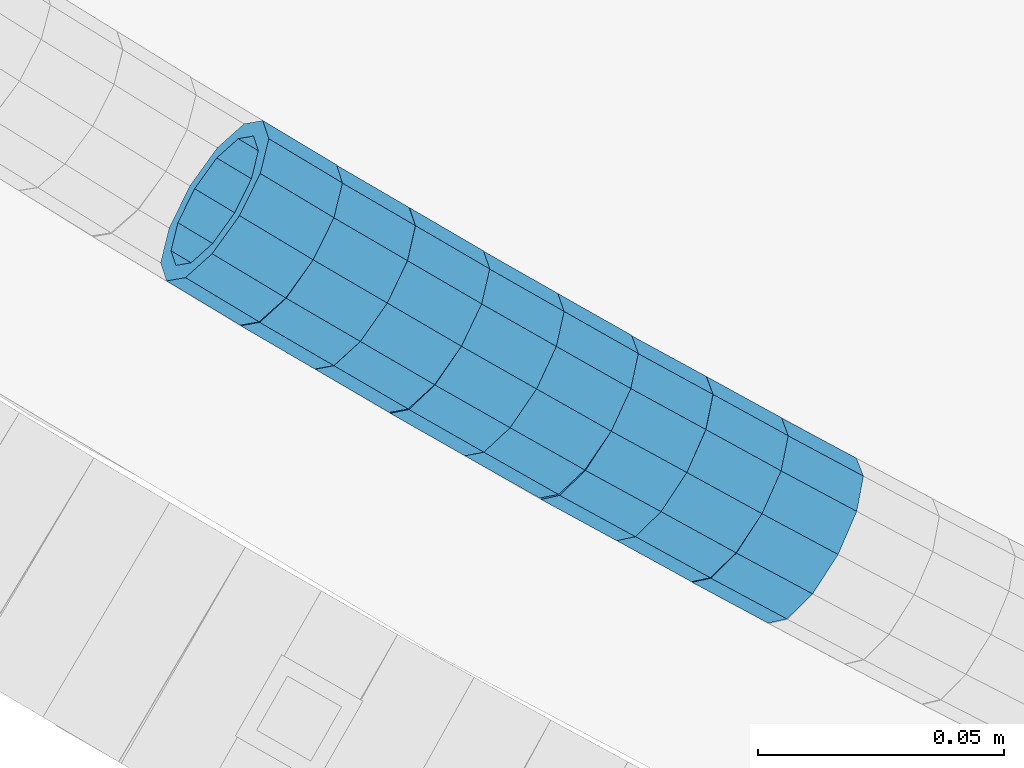
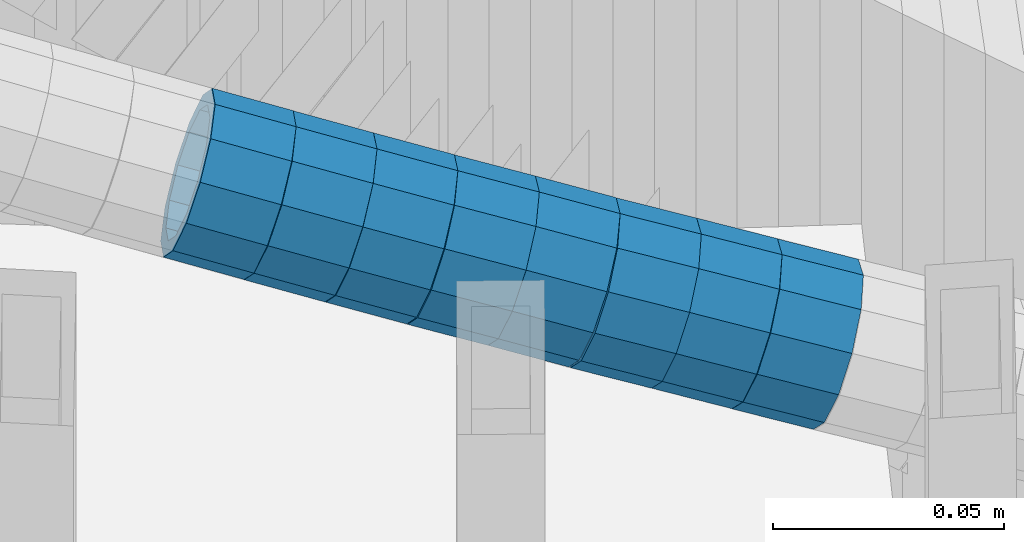
# One storey, part 646 of 975: 8 beams.
"""IFC2X3 building model written with IfcOpenShell, lengths in millimetres."""

from ifc_helpers import new_model, si_unit, frame, origin_with_axes, place, context, subcontext, project, spatial, faceted_brep, material, type_object, element, save


model = new_model("IFC2X3")

# Units and contexts
model_context = context("Model", 3, precision=1e-05, world=origin_with_axes())
body_context = subcontext(model_context, "Body", "Model", "MODEL_VIEW")
ifc_project = project(units=[si_unit("LENGTHUNIT", "METRE", prefix="MILLI"), si_unit("AREAUNIT", "SQUARE_METRE"), si_unit("VOLUMEUNIT", "CUBIC_METRE"), si_unit("MASSUNIT", "GRAM", prefix="KILO"), si_unit("TIMEUNIT", "SECOND"), si_unit("PLANEANGLEUNIT", "RADIAN"), si_unit("SOLIDANGLEUNIT", "STERADIAN"), si_unit("THERMODYNAMICTEMPERATUREUNIT", "DEGREE_CELSIUS"), si_unit("LUMINOUSINTENSITYUNIT", "LUMEN")], contexts=[model_context])

# Site, building, storey
site_placement = place(None, origin_with_axes())
site = spatial("IfcSite", under=ifc_project, at=site_placement, CompositionType="ELEMENT")
building_placement = place(site_placement, origin_with_axes())
building = spatial("IfcBuilding", under=site, at=building_placement, Name="Undefined", CompositionType="ELEMENT")
storey_placement = place(building_placement, origin_with_axes())
storey = spatial("IfcBuildingStorey", under=building, at=storey_placement, Name="Undefined", CompositionType="ELEMENT", Elevation=0.0)

# Beams
ifc_material = material()
beam_type = type_object("IfcBeamType", PredefinedType="NOTDEFINED")
beam_1_placement = place(storey_placement, frame((33294.3357173171, 1016.54392935502, 4704.68731766489), z_axis=(0.514495754965712, 0.857492925989633, 7.84348230808974e-12), x_axis=(0.815301680931507, -0.489181007958907, -0.309814638973963)))
element("IfcBeam", 1, at=beam_1_placement, inside=storey, type_object=beam_type, material=ifc_material, Name="WALL", context=body_context, shape_type="Brep", body=[
    faceted_brep([(-2.1246523829177e-07, -15.367000000002, 0.0), (-1.83998054126278e-07, -13.3082123799541, 7.68350000000009), (18.4002717371586, -13.3082123799486, 7.6835000000101), (18.4002717371732, -15.3670000000002, 2.5465851649642e-11), (-1.06232619145885e-07, -7.68349999999919, 13.3082123799559), (18.4002717371368, -7.68349999998645, 13.3082123799431), (-3.63797880709171e-12, 3.63797880709171e-12, 15.3670000000002), (18.400271737115, 2.00088834390044e-11, 15.3669999999656), (1.06225343188271e-07, 7.68350000000646, 13.3082123799559), (18.4002717371004, 7.68350000002283, 13.3082123799068), (1.8399441614747e-07, 13.308212379965, 7.68350000000009), (18.4002717370895, 13.3082123799741, 7.68349999994462), (2.12461600312963e-07, 15.3670000000093, 0.0), (18.4002717370931, 15.3670000000147, -5.45696821063757e-11), (1.8399441614747e-07, 13.308212379965, -7.68350000000009), (18.4002717371004, 13.3082123799632, -7.6835000000392), (1.06225343188271e-07, 7.68350000000646, -13.3082123799559), (18.4002717371259, 7.68349999999919, -13.3082123799759), (-3.63797880709171e-12, 3.63797880709171e-12, -15.3670000000002), (18.4002717371513, -5.45696821063757e-12, -15.3669999999984), (-1.06232619145885e-07, -7.68349999999919, -13.3082123799559), (18.4002717371659, -7.68350000000646, -13.3082123799395), (-1.83998054126278e-07, -13.3082123799541, -7.68350000000009), (18.4002717371732, -13.3082123799613, -7.68349999997736), (-2.63386027654633e-07, -19.0500000000029, 0.0), (-2.28097633225843e-07, -16.4977839420972, -9.52499999999964), (18.4002717371877, -16.4977839421026, -9.52499999996508), (18.4002717371841, -19.0500000000029, 3.63797880709171e-11), (-1.31691194837913e-07, -9.52500000000146, -16.4977839420935), (18.4002717371768, -9.52500000001055, -16.4977839420681), (-3.63797880709171e-12, 3.63797880709171e-12, -19.0500000000002), (18.400271737155, -9.09494701772928e-12, -19.0499999999956), (1.31687556859106e-07, 9.52500000000509, -16.4977839420935), (18.4002717371295, 9.52499999999782, -16.4977839421153), (2.28097633225843e-07, 16.4977839421044, -9.52499999999964), (18.4002717370968, 16.4977839421026, -9.52500000005239), (2.63382389675826e-07, 19.0500000000138, 0.0), (18.4002717370822, 19.0500000000156, -6.54836185276508e-11), (2.28097633225843e-07, 16.4977839421044, 9.52499999999964), (18.4002717370786, 16.4977839421172, 9.52499999993233), (1.31687556859106e-07, 9.52500000000509, 16.4977839420935), (18.4002717370859, 9.5250000000251, 16.497783942039), (-3.63797880709171e-12, 3.63797880709171e-12, 19.0500000000002), (18.4002717371113, 2.36468622460961e-11, 19.0499999999629), (-1.31691194837913e-07, -9.52500000000146, 16.4977839420935), (18.4002717371368, -9.52499999998327, 16.4977839420826), (-2.28097633225843e-07, -16.4977839420972, 9.52499999999964), (18.4002717371623, -16.4977839420844, 9.52500000001601)], [[[0, 1, 2, 3]], [[1, 4, 5, 2]], [[4, 6, 7, 5]], [[6, 8, 9, 7]], [[8, 10, 11, 9]], [[10, 12, 13, 11]], [[12, 14, 15, 13]], [[14, 16, 17, 15]], [[16, 18, 19, 17]], [[18, 20, 21, 19]], [[20, 22, 23, 21]], [[22, 0, 3, 23]], [[24, 25, 26, 27]], [[25, 28, 29, 26]], [[28, 30, 31, 29]], [[30, 32, 33, 31]], [[32, 34, 35, 33]], [[34, 36, 37, 35]], [[36, 38, 39, 37]], [[38, 40, 41, 39]], [[40, 42, 43, 41]], [[42, 44, 45, 43]], [[44, 46, 47, 45]], [[46, 24, 27, 47]], [[29, 31, 33, 35, 37, 39, 41, 43, 45, 47, 27, 26], [5, 7, 9, 11, 13, 15, 17, 19, 21, 23, 3, 2]], [[46, 44, 42, 40, 38, 36, 34, 32, 30, 28, 25, 24], [22, 20, 18, 16, 14, 12, 10, 8, 6, 4, 1, 0]]]),
])
beam_2_placement = place(storey_placement, frame((33309.2125258696, 1007.52858178118, 4699.01962007221), z_axis=(0.503515225322365, 0.863986352825418, -1.21602170111146e-10), x_axis=(0.820010580827939, -0.47788696089976, -0.314970950933919)))
element("IfcBeam", 2, at=beam_2_placement, inside=storey, type_object=beam_type, material=ifc_material, Name="WALL", context=body_context, shape_type="Brep", body=[
    faceted_brep([(-2.1246523829177e-07, -15.367000000002, 0.0), (-1.83998054126278e-07, -13.3082123799541, 7.68350000000009), (18.4143965418989, -13.3082123799722, 7.68350000004284), (18.4143965419134, -15.3670000000257, 5.82076609134674e-11), (-1.06232619145885e-07, -7.68349999999919, 13.3082123799559), (18.4143965418734, -7.68350000000646, 13.3082123799759), (-3.63797880709171e-12, 3.63797880709171e-12, 15.3670000000002), (18.414396541848, 3.63797880709171e-12, 15.3669999999984), (1.06225343188271e-07, 7.68350000000646, 13.3082123799559), (18.4143965418334, 7.6835000000101, 13.3082123799395), (1.8399441614747e-07, 13.308212379965, 7.68350000000009), (18.4143965418261, 13.3082123799686, 7.68349999997736), (2.12461600312963e-07, 15.3670000000093, 0.0), (18.4143965418334, 15.3670000000093, -1.81898940354586e-11), (1.8399441614747e-07, 13.308212379965, -7.68350000000009), (18.4143965418552, 13.3082123799577, -7.68349999999919), (1.06225343188271e-07, 7.68350000000646, -13.3082123799559), (18.4143965418734, 7.68349999999191, -13.3082123799322), (-3.63797880709171e-12, 3.63797880709171e-12, -15.3670000000002), (18.4143965418989, -2.00088834390044e-11, -15.3669999999584), (-1.06232619145885e-07, -7.68349999999919, -13.3082123799559), (18.4143965419134, -7.68350000002829, -13.3082123798958), (-1.83998054126278e-07, -13.3082123799541, -7.68350000000009), (18.4143965419207, -13.3082123799832, -7.6834999999337), (-2.63386027654633e-07, -19.0500000000029, 0.0), (-2.28097633225843e-07, -16.4977839420972, -9.52499999999964), (18.4143965419316, -16.4977839421263, -9.5249999999287), (18.4143965419207, -19.0500000000284, 6.54836185276508e-11), (-1.31691194837913e-07, -9.52500000000146, -16.4977839420935), (18.4143965419207, -9.52500000003056, -16.497783942028), (-3.63797880709171e-12, 3.63797880709171e-12, -19.0500000000002), (18.4143965419025, -2.18278728425503e-11, -19.049999999952), (1.31687556859106e-07, 9.52500000000509, -16.4977839420935), (18.4143965418771, 9.52499999999054, -16.4977839420717), (2.28097633225843e-07, 16.4977839421044, -9.52499999999964), (18.414396541848, 16.4977839420972, -9.52500000000146), (2.63382389675826e-07, 19.0500000000138, 0.0), (18.4143965418298, 19.050000000012, -2.18278728425503e-11), (2.28097633225843e-07, 16.4977839421044, 9.52499999999964), (18.4143965418225, 16.4977839421117, 9.52499999997235), (1.31687556859106e-07, 9.52500000000509, 16.4977839420935), (18.4143965418225, 9.52500000001601, 16.4977839420681), (-3.63797880709171e-12, 3.63797880709171e-12, 19.0500000000002), (18.4143965418443, 7.27595761418343e-12, 19.0499999999956), (-1.31691194837913e-07, -9.52500000000146, 16.4977839420935), (18.4143965418734, -9.52500000000691, 16.4977839421153), (-2.28097633225843e-07, -16.4977839420972, 9.52499999999964), (18.4143965418989, -16.4977839421117, 9.52500000004511)], [[[0, 1, 2, 3]], [[1, 4, 5, 2]], [[4, 6, 7, 5]], [[6, 8, 9, 7]], [[8, 10, 11, 9]], [[10, 12, 13, 11]], [[12, 14, 15, 13]], [[14, 16, 17, 15]], [[16, 18, 19, 17]], [[18, 20, 21, 19]], [[20, 22, 23, 21]], [[22, 0, 3, 23]], [[24, 25, 26, 27]], [[25, 28, 29, 26]], [[28, 30, 31, 29]], [[30, 32, 33, 31]], [[32, 34, 35, 33]], [[34, 36, 37, 35]], [[36, 38, 39, 37]], [[38, 40, 41, 39]], [[40, 42, 43, 41]], [[42, 44, 45, 43]], [[44, 46, 47, 45]], [[46, 24, 27, 47]], [[29, 31, 33, 35, 37, 39, 41, 43, 45, 47, 27, 26], [5, 7, 9, 11, 13, 15, 17, 19, 21, 23, 3, 2]], [[46, 44, 42, 40, 38, 36, 34, 32, 30, 28, 25, 24], [22, 20, 18, 16, 14, 12, 10, 8, 6, 4, 1, 0]]]),
])
beam_3_placement = place(storey_placement, frame((33324.3932454891, 998.681539883716, 4693.18888269571), z_axis=(0.503515225322365, 0.863986352825418, -1.21602170111146e-10), x_axis=(0.821404631850218, -0.478699387912686, -0.310066648943462)))
element("IfcBeam", 3, at=beam_3_placement, inside=storey, type_object=beam_type, material=ifc_material, Name="WALL", context=body_context, shape_type="Brep", body=[
    faceted_brep([(-2.1246523829177e-07, -15.367000000002, 0.0), (-1.83998054126278e-07, -13.3082123799541, 7.68350000000009), (18.3831444535936, -13.3082123799741, 7.68350000002465), (18.3831444535717, -15.3670000000056, 7.27595761418343e-12), (-1.06232619145885e-07, -7.68349999999919, 13.3082123799559), (18.3831444536154, -7.68350000002283, 13.3082123799941), (-3.63797880709171e-12, 3.63797880709171e-12, 15.3670000000002), (18.3831444536409, -3.09228198602796e-11, 15.3670000000493), (1.06225343188271e-07, 7.68350000000646, 13.3082123799559), (18.3831444536554, 7.68349999996462, 13.3082123800159), (1.8399441614747e-07, 13.308212379965, 7.68350000000009), (18.3831444536554, 13.3082123799231, 7.68350000006103), (2.12461600312963e-07, 15.3670000000093, 0.0), (18.3831444536409, 15.3669999999747, 5.0931703299284e-11), (1.8399441614747e-07, 13.308212379965, -7.68350000000009), (18.3831444536154, 13.3082123799413, -7.68349999996281), (1.06225343188271e-07, 7.68350000000646, -13.3082123799559), (18.3831444535899, 7.68349999999737, -13.3082123799359), (-3.63797880709171e-12, 3.63797880709171e-12, -15.3670000000002), (18.3831444535681, 5.45696821063757e-12, -15.3669999999947), (-1.06232619145885e-07, -7.68349999999919, -13.3082123799559), (18.3831444535608, -7.68349999999737, -13.3082123799577), (-1.83998054126278e-07, -13.3082123799541, -7.68350000000009), (18.3831444535535, -13.3082123799522, -7.68350000000282), (-2.63386027654633e-07, -19.0500000000029, 0.0), (-2.28097633225843e-07, -16.4977839420972, -9.52499999999964), (18.3831444535426, -16.4977839420862, -9.52500000000873), (18.3831444535608, -19.0500000000047, 3.63797880709171e-12), (-1.31691194837913e-07, -9.52500000000146, -16.4977839420935), (18.383144453539, -9.52499999998872, -16.4977839421081), (-3.63797880709171e-12, 3.63797880709171e-12, -19.0500000000002), (18.3831444535572, 9.09494701772928e-12, -19.0500000000029), (1.31687556859106e-07, 9.52500000000509, -16.4977839420935), (18.3831444535863, 9.52499999999964, -16.497783942079), (2.28097633225843e-07, 16.4977839421044, -9.52499999999964), (18.383144453619, 16.4977839420808, -9.52499999996508), (2.63382389675826e-07, 19.0500000000138, 0.0), (18.3831444536481, 19.049999999972, 5.45696821063757e-11), (2.28097633225843e-07, 16.4977839421044, 9.52499999999964), (18.3831444536663, 16.4977839420571, 9.52500000006694), (1.31687556859106e-07, 9.52500000000509, 16.4977839420935), (18.3831444536663, 9.52499999996144, 16.4977839421626), (-3.63797880709171e-12, 3.63797880709171e-12, 19.0500000000002), (18.3831444536518, -3.45607986673713e-11, 19.0500000000575), (-1.31691194837913e-07, -9.52500000000146, 16.4977839420935), (18.3831444536263, -9.52500000002874, 16.4977839421372), (-2.28097633225843e-07, -16.4977839420972, 9.52499999999964), (18.3831444535863, -16.4977839421099, 9.52500000001965)], [[[0, 1, 2, 3]], [[1, 4, 5, 2]], [[4, 6, 7, 5]], [[6, 8, 9, 7]], [[8, 10, 11, 9]], [[10, 12, 13, 11]], [[12, 14, 15, 13]], [[14, 16, 17, 15]], [[16, 18, 19, 17]], [[18, 20, 21, 19]], [[20, 22, 23, 21]], [[22, 0, 3, 23]], [[24, 25, 26, 27]], [[25, 28, 29, 26]], [[28, 30, 31, 29]], [[30, 32, 33, 31]], [[32, 34, 35, 33]], [[34, 36, 37, 35]], [[36, 38, 39, 37]], [[38, 40, 41, 39]], [[40, 42, 43, 41]], [[42, 44, 45, 43]], [[44, 46, 47, 45]], [[46, 24, 27, 47]], [[29, 31, 33, 35, 37, 39, 41, 43, 45, 47, 27, 26], [5, 7, 9, 11, 13, 15, 17, 19, 21, 23, 3, 2]], [[46, 44, 42, 40, 38, 36, 34, 32, 30, 28, 25, 24], [22, 20, 18, 16, 14, 12, 10, 8, 6, 4, 1, 0]]]),
])
beam_4_placement = place(storey_placement, frame((33339.4944998302, 989.808593524436, 4687.47670127713), z_axis=(0.494302224083963, 0.869290119157953, 1.64800439961254e-12), x_axis=(0.827002863921509, -0.470256529955359, -0.308099105970736)))
element("IfcBeam", 4, at=beam_4_placement, inside=storey, type_object=beam_type, material=ifc_material, Name="WALL", context=body_context, shape_type="Brep", body=[
    faceted_brep([(-2.1246523829177e-07, -15.367000000002, 0.0), (-1.83998054126278e-07, -13.3082123799541, 7.68350000000009), (18.5005405327211, -13.3082123799777, 7.68350000005012), (18.5005405327393, -15.3670000000293, 6.54836185276508e-11), (-1.06232619145885e-07, -7.68349999999919, 13.3082123799559), (18.5005405326992, -7.68350000001737, 13.3082123799904), (-3.63797880709171e-12, 3.63797880709171e-12, 15.3670000000002), (18.5005405326847, -1.2732925824821e-11, 15.3670000000238), (1.06225343188271e-07, 7.68350000000646, 13.3082123799559), (18.5005405326665, 7.68349999999009, 13.308212379965), (1.8399441614747e-07, 13.308212379965, 7.68350000000009), (18.5005405326592, 13.3082123799468, 7.68349999999919), (2.12461600312963e-07, 15.3670000000093, 0.0), (18.5005405326629, 15.3669999999893, 7.27595761418343e-12), (1.8399441614747e-07, 13.308212379965, -7.68350000000009), (18.5005405326738, 13.3082123799413, -7.683499999981), (1.06225343188271e-07, 7.68350000000646, -13.3082123799559), (18.500540532692, 7.68349999997736, -13.3082123799177), (-3.63797880709171e-12, 3.63797880709171e-12, -15.3670000000002), (18.5005405327211, -2.91038304567337e-11, -15.3669999999438), (-1.06232619145885e-07, -7.68349999999919, -13.3082123799559), (18.500540532732, -7.68350000003375, -13.3082123798886), (-1.83998054126278e-07, -13.3082123799541, -7.68350000000009), (18.5005405327429, -13.3082123799886, -7.68349999992643), (-2.63386027654633e-07, -19.0500000000029, 0.0), (-2.28097633225843e-07, -16.4977839420972, -9.52499999999964), (18.5005405327502, -16.4977839421281, -9.52499999991778), (18.5005405327465, -19.0500000000338, 7.27595761418343e-11), (-1.31691194837913e-07, -9.52500000000146, -16.4977839420935), (18.5005405327429, -9.52500000003602, -16.4977839420171), (-3.63797880709171e-12, 3.63797880709171e-12, -19.0500000000002), (18.5005405327211, -3.09228198602796e-11, -19.0499999999411), (1.31687556859106e-07, 9.52500000000509, -16.4977839420935), (18.500540532692, 9.52499999997599, -16.4977839420571), (2.28097633225843e-07, 16.4977839421044, -9.52499999999964), (18.5005405326701, 16.4977839420771, -9.52499999998327), (2.63382389675826e-07, 19.0500000000138, 0.0), (18.5005405326519, 19.0499999999902, 0.0), (2.28097633225843e-07, 16.4977839421044, 9.52499999999964), (18.5005405326447, 16.4977839420881, 9.52499999999418), (1.31687556859106e-07, 9.52500000000509, 16.4977839420935), (18.5005405326556, 9.524999999996, 16.4977839420899), (-3.63797880709171e-12, 3.63797880709171e-12, 19.0500000000002), (18.5005405326738, -9.09494701772928e-12, 19.0500000000138), (-1.31691194837913e-07, -9.52500000000146, 16.4977839420935), (18.5005405327065, -9.52500000001783, 16.4977839421335), (-2.28097633225843e-07, -16.4977839420972, 9.52499999999964), (18.5005405327247, -16.497783942119, 9.52500000005602)], [[[0, 1, 2, 3]], [[1, 4, 5, 2]], [[4, 6, 7, 5]], [[6, 8, 9, 7]], [[8, 10, 11, 9]], [[10, 12, 13, 11]], [[12, 14, 15, 13]], [[14, 16, 17, 15]], [[16, 18, 19, 17]], [[18, 20, 21, 19]], [[20, 22, 23, 21]], [[22, 0, 3, 23]], [[24, 25, 26, 27]], [[25, 28, 29, 26]], [[28, 30, 31, 29]], [[30, 32, 33, 31]], [[32, 34, 35, 33]], [[34, 36, 37, 35]], [[36, 38, 39, 37]], [[38, 40, 41, 39]], [[40, 42, 43, 41]], [[42, 44, 45, 43]], [[44, 46, 47, 45]], [[46, 24, 27, 47]], [[29, 31, 33, 35, 37, 39, 41, 43, 45, 47, 27, 26], [5, 7, 9, 11, 13, 15, 17, 19, 21, 23, 3, 2]], [[46, 44, 42, 40, 38, 36, 34, 32, 30, 28, 25, 24], [22, 20, 18, 16, 14, 12, 10, 8, 6, 4, 1, 0]]]),
])
beam_5_placement = place(storey_placement, frame((33354.6708772862, 981.164058174754, 4681.82094314435), z_axis=(0.492434567421078, 0.870349468207349, 2.01246621145401e-10), x_axis=(0.825989373786225, -0.467336092879068, -0.315180155918432)))
element("IfcBeam", 5, at=beam_5_placement, inside=storey, type_object=beam_type, material=ifc_material, Name="WALL", context=body_context, shape_type="Brep", body=[
    faceted_brep([(-2.1246523829177e-07, -15.367000000002, 0.0), (-1.83998054126278e-07, -13.3082123799541, 7.68350000000009), (18.4002717371586, -13.3082123799486, 7.6835000000101), (18.4002717371732, -15.3670000000002, 2.5465851649642e-11), (-1.06232619145885e-07, -7.68349999999919, 13.3082123799559), (18.4002717371368, -7.68349999998645, 13.3082123799431), (-3.63797880709171e-12, 3.63797880709171e-12, 15.3670000000002), (18.400271737115, 2.00088834390044e-11, 15.3669999999656), (1.06225343188271e-07, 7.68350000000646, 13.3082123799559), (18.4002717371004, 7.68350000002283, 13.3082123799068), (1.8399441614747e-07, 13.308212379965, 7.68350000000009), (18.4002717370895, 13.3082123799741, 7.68349999994462), (2.12461600312963e-07, 15.3670000000093, 0.0), (18.4002717370931, 15.3670000000147, -5.45696821063757e-11), (1.8399441614747e-07, 13.308212379965, -7.68350000000009), (18.4002717371004, 13.3082123799632, -7.6835000000392), (1.06225343188271e-07, 7.68350000000646, -13.3082123799559), (18.4002717371259, 7.68349999999919, -13.3082123799759), (-3.63797880709171e-12, 3.63797880709171e-12, -15.3670000000002), (18.4002717371513, -5.45696821063757e-12, -15.3669999999984), (-1.06232619145885e-07, -7.68349999999919, -13.3082123799559), (18.4002717371659, -7.68350000000646, -13.3082123799395), (-1.83998054126278e-07, -13.3082123799541, -7.68350000000009), (18.4002717371732, -13.3082123799613, -7.68349999997736), (-2.63386027654633e-07, -19.0500000000029, 0.0), (-2.28097633225843e-07, -16.4977839420972, -9.52499999999964), (18.4002717371877, -16.4977839421026, -9.52499999996508), (18.4002717371841, -19.0500000000029, 3.63797880709171e-11), (-1.31691194837913e-07, -9.52500000000146, -16.4977839420935), (18.4002717371768, -9.52500000001055, -16.4977839420681), (-3.63797880709171e-12, 3.63797880709171e-12, -19.0500000000002), (18.400271737155, -9.09494701772928e-12, -19.0499999999956), (1.31687556859106e-07, 9.52500000000509, -16.4977839420935), (18.4002717371295, 9.52499999999782, -16.4977839421153), (2.28097633225843e-07, 16.4977839421044, -9.52499999999964), (18.4002717370968, 16.4977839421026, -9.52500000005239), (2.63382389675826e-07, 19.0500000000138, 0.0), (18.4002717370822, 19.0500000000156, -6.54836185276508e-11), (2.28097633225843e-07, 16.4977839421044, 9.52499999999964), (18.4002717370786, 16.4977839421172, 9.52499999993233), (1.31687556859106e-07, 9.52500000000509, 16.4977839420935), (18.4002717370859, 9.5250000000251, 16.497783942039), (-3.63797880709171e-12, 3.63797880709171e-12, 19.0500000000002), (18.4002717371113, 2.36468622460961e-11, 19.0499999999629), (-1.31691194837913e-07, -9.52500000000146, 16.4977839420935), (18.4002717371368, -9.52499999998327, 16.4977839420826), (-2.28097633225843e-07, -16.4977839420972, 9.52499999999964), (18.4002717371623, -16.4977839420844, 9.52500000001601)], [[[0, 1, 2, 3]], [[1, 4, 5, 2]], [[4, 6, 7, 5]], [[6, 8, 9, 7]], [[8, 10, 11, 9]], [[10, 12, 13, 11]], [[12, 14, 15, 13]], [[14, 16, 17, 15]], [[16, 18, 19, 17]], [[18, 20, 21, 19]], [[20, 22, 23, 21]], [[22, 0, 3, 23]], [[24, 25, 26, 27]], [[25, 28, 29, 26]], [[28, 30, 31, 29]], [[30, 32, 33, 31]], [[32, 34, 35, 33]], [[34, 36, 37, 35]], [[36, 38, 39, 37]], [[38, 40, 41, 39]], [[40, 42, 43, 41]], [[42, 44, 45, 43]], [[44, 46, 47, 45]], [[46, 24, 27, 47]], [[29, 31, 33, 35, 37, 39, 41, 43, 45, 47, 27, 26], [5, 7, 9, 11, 13, 15, 17, 19, 21, 23, 3, 2]], [[46, 44, 42, 40, 38, 36, 34, 32, 30, 28, 25, 24], [22, 20, 18, 16, 14, 12, 10, 8, 6, 4, 1, 0]]]),
])
beam_6_placement = place(storey_placement, frame((33369.9284157076, 972.426408602935, 4675.98245690488), z_axis=(0.478852130900544, 0.8778955727944, -3.61887941835448e-12), x_axis=(0.834924458035718, -0.455413341019474, -0.30903048101319)))
element("IfcBeam", 6, at=beam_6_placement, inside=storey, type_object=beam_type, material=ifc_material, Name="WALL", context=body_context, shape_type="Brep", body=[
    faceted_brep([(-2.1246523829177e-07, -15.367000000002, 0.0), (-1.83998054126278e-07, -13.3082123799541, 7.68350000000009), (18.4442402933746, -13.3082123799431, 7.68349999998463), (18.4442402933928, -15.3669999999893, -3.63797880709171e-12), (-1.06232619145885e-07, -7.68349999999919, 13.3082123799559), (18.4442402933564, -7.68349999998281, 13.308212379925), (-3.63797880709171e-12, 3.63797880709171e-12, 15.3670000000002), (18.4442402933455, 1.81898940354586e-11, 15.3669999999584), (1.06225343188271e-07, 7.68350000000646, 13.3082123799559), (18.4442402933419, 7.68350000001737, 13.3082123799104), (1.8399441614747e-07, 13.308212379965, 7.68350000000009), (18.4442402933528, 13.3082123799722, 7.68349999996281), (2.12461600312963e-07, 15.3670000000093, 0.0), (18.4442402933637, 15.3670000000129, -2.5465851649642e-11), (1.8399441614747e-07, 13.308212379965, -7.68350000000009), (18.4442402933855, 13.308212379965, -7.6835000000101), (1.06225343188271e-07, 7.68350000000646, -13.3082123799559), (18.4442402934037, 7.68350000000646, -13.3082123799541), (-3.63797880709171e-12, 3.63797880709171e-12, -15.3670000000002), (18.444240293411, 5.45696821063757e-12, -15.3669999999911), (-1.06232619145885e-07, -7.68349999999919, -13.3082123799559), (18.4442402934146, -7.68349999999373, -13.3082123799431), (-1.83998054126278e-07, -13.3082123799541, -7.68350000000009), (18.4442402934037, -13.3082123799468, -7.68349999999191), (-2.63386027654633e-07, -19.0500000000029, 0.0), (-2.28097633225843e-07, -16.4977839420972, -9.52499999999964), (18.444240293411, -16.4977839420862, -9.5249999999869), (18.4442402933964, -19.0499999999902, 0.0), (-1.31691194837913e-07, -9.52500000000146, -16.4977839420935), (18.4442402934219, -9.524999999996, -16.4977839420717), (-3.63797880709171e-12, 3.63797880709171e-12, -19.0500000000002), (18.4442402934183, 3.63797880709171e-12, -19.0499999999847), (1.31687556859106e-07, 9.52500000000509, -16.4977839420935), (18.4442402934073, 9.52500000000509, -16.4977839420899), (2.28097633225843e-07, 16.4977839421044, -9.52499999999964), (18.4442402933855, 16.4977839421008, -9.52500000001601), (2.63382389675826e-07, 19.0500000000138, 0.0), (18.4442402933637, 19.0500000000138, -2.91038304567337e-11), (2.28097633225843e-07, 16.4977839421044, 9.52499999999964), (18.4442402933419, 16.4977839421117, 9.52499999995052), (1.31687556859106e-07, 9.52500000000509, 16.4977839420935), (18.4442402933346, 9.52500000001965, 16.4977839420426), (-3.63797880709171e-12, 3.63797880709171e-12, 19.0500000000002), (18.4442402933346, 2.00088834390044e-11, 19.0499999999483), (-1.31691194837913e-07, -9.52500000000146, 16.4977839420935), (18.4442402933528, -9.52499999998145, 16.4977839420571), (-2.28097633225843e-07, -16.4977839420972, 9.52499999999964), (18.4442402933746, -16.497783942079, 9.52499999998327)], [[[0, 1, 2, 3]], [[1, 4, 5, 2]], [[4, 6, 7, 5]], [[6, 8, 9, 7]], [[8, 10, 11, 9]], [[10, 12, 13, 11]], [[12, 14, 15, 13]], [[14, 16, 17, 15]], [[16, 18, 19, 17]], [[18, 20, 21, 19]], [[20, 22, 23, 21]], [[22, 0, 3, 23]], [[24, 25, 26, 27]], [[25, 28, 29, 26]], [[28, 30, 31, 29]], [[30, 32, 33, 31]], [[32, 34, 35, 33]], [[34, 36, 37, 35]], [[36, 38, 39, 37]], [[38, 40, 41, 39]], [[40, 42, 43, 41]], [[42, 44, 45, 43]], [[44, 46, 47, 45]], [[46, 24, 27, 47]], [[29, 31, 33, 35, 37, 39, 41, 43, 45, 47, 27, 26], [5, 7, 9, 11, 13, 15, 17, 19, 21, 23, 3, 2]], [[46, 44, 42, 40, 38, 36, 34, 32, 30, 28, 25, 24], [22, 20, 18, 16, 14, 12, 10, 8, 6, 4, 1, 0]]]),
])
beam_7_placement = place(storey_placement, frame((33400.5356013736, 955.624578760234, 4664.60890547986), z_axis=(0.472063574609281, 0.881564507864914, 9.25883796298876e-11), x_axis=(0.837189863051517, -0.448301668027572, -0.313271045019292)))
element("IfcBeam", 7, at=beam_7_placement, inside=storey, type_object=beam_type, material=ifc_material, Name="WALL", context=body_context, shape_type="Brep", body=[
    faceted_brep([(-2.1246523829177e-07, -15.367000000002, 0.0), (-1.83998054126278e-07, -13.3082123799541, 7.68350000000009), (18.5143187830763, -13.3082123799722, 7.68350000001374), (18.5143187830618, -15.3670000000093, 3.63797880709171e-12), (-1.06232619145885e-07, -7.68349999999919, 13.3082123799559), (18.5143187830836, -7.68350000002101, 13.3082123799722), (-3.63797880709171e-12, 3.63797880709171e-12, 15.3670000000002), (18.5143187830763, -1.81898940354586e-11, 15.3670000000166), (1.06225343188271e-07, 7.68350000000646, 13.3082123799559), (18.5143187830581, 7.68349999999009, 13.3082123799613), (1.8399441614747e-07, 13.308212379965, 7.68350000000009), (18.5143187830363, 13.3082123799559, 7.68349999999191), (2.12461600312963e-07, 15.3670000000093, 0.0), (18.5143187830108, 15.3670000000111, -2.18278728425503e-11), (1.8399441614747e-07, 13.308212379965, -7.68350000000009), (18.514318782989, 13.3082123799722, -7.68350000003193), (1.06225343188271e-07, 7.68350000000646, -13.3082123799559), (18.5143187829854, 7.68350000002101, -13.3082123799904), (-3.63797880709171e-12, 3.63797880709171e-12, -15.3670000000002), (18.5143187829926, 1.81898940354586e-11, -15.3670000000311), (-1.06232619145885e-07, -7.68349999999919, -13.3082123799559), (18.5143187830108, -7.68349999999191, -13.3082123799795), (-1.83998054126278e-07, -13.3082123799541, -7.68350000000009), (18.5143187830363, -13.3082123799559, -7.6835000000101), (-2.63386027654633e-07, -19.0500000000029, 0.0), (-2.28097633225843e-07, -16.4977839420972, -9.52499999999964), (18.5143187830363, -16.4977839420935, -9.52500000000873), (18.5143187830654, -19.0500000000102, 7.27595761418343e-12), (-1.31691194837913e-07, -9.52500000000146, -16.4977839420935), (18.5143187830035, -9.5249999999869, -16.497783942119), (-3.63797880709171e-12, 3.63797880709171e-12, -19.0500000000002), (18.5143187829854, 2.00088834390044e-11, -19.0500000000357), (1.31687556859106e-07, 9.52500000000509, -16.4977839420935), (18.5143187829744, 9.5250000000251, -16.4977839421408), (2.28097633225843e-07, 16.4977839421044, -9.52499999999964), (18.5143187829854, 16.4977839421135, -9.52500000003783), (2.63382389675826e-07, 19.0500000000138, 0.0), (18.5143187830035, 19.050000000012, -2.5465851649642e-11), (2.28097633225843e-07, 16.4977839421044, 9.52499999999964), (18.5143187830326, 16.4977839420935, 9.52499999999054), (1.31687556859106e-07, 9.52500000000509, 16.4977839420935), (18.5143187830654, 9.52499999998872, 16.4977839421008), (-3.63797880709171e-12, 3.63797880709171e-12, 19.0500000000002), (18.5143187830836, -1.81898940354586e-11, 19.0500000000211), (-1.31691194837913e-07, -9.52500000000146, 16.4977839420935), (18.5143187830981, -9.52500000002328, 16.4977839421226), (-2.28097633225843e-07, -16.4977839420972, 9.52499999999964), (18.5143187830872, -16.4977839421135, 9.52500000001965)], [[[0, 1, 2, 3]], [[1, 4, 5, 2]], [[4, 6, 7, 5]], [[6, 8, 9, 7]], [[8, 10, 11, 9]], [[10, 12, 13, 11]], [[12, 14, 15, 13]], [[14, 16, 17, 15]], [[16, 18, 19, 17]], [[18, 20, 21, 19]], [[20, 22, 23, 21]], [[22, 0, 3, 23]], [[24, 25, 26, 27]], [[25, 28, 29, 26]], [[28, 30, 31, 29]], [[30, 32, 33, 31]], [[32, 34, 35, 33]], [[34, 36, 37, 35]], [[36, 38, 39, 37]], [[38, 40, 41, 39]], [[40, 42, 43, 41]], [[42, 44, 45, 43]], [[44, 46, 47, 45]], [[46, 24, 27, 47]], [[29, 31, 33, 35, 37, 39, 41, 43, 45, 47, 27, 26], [5, 7, 9, 11, 13, 15, 17, 19, 21, 23, 3, 2]], [[46, 44, 42, 40, 38, 36, 34, 32, 30, 28, 25, 24], [22, 20, 18, 16, 14, 12, 10, 8, 6, 4, 1, 0]]]),
])
beam_8_placement = place(storey_placement, frame((33385.3127267734, 964.053447084345, 4670.29116846247), z_axis=(0.48125881238433, 0.876578550674396, -1.61192474479321e-10), x_axis=(0.833271042168782, -0.457482141092678, -0.31043431006287)))
element("IfcBeam", 8, at=beam_8_placement, inside=storey, type_object=beam_type, material=ifc_material, Name="WALL", context=body_context, shape_type="Brep", body=[
    faceted_brep([(-2.1246523829177e-07, -15.367000000002, 0.0), (-1.83998054126278e-07, -13.3082123799541, 7.68350000000009), (18.361644806515, -13.308212379945, 7.68349999999555), (18.3616448065295, -15.3669999999893, 7.27595761418343e-12), (-1.06232619145885e-07, -7.68349999999919, 13.3082123799559), (18.3616448064895, -7.68349999998281, 13.3082123799359), (-3.63797880709171e-12, 3.63797880709171e-12, 15.3670000000002), (18.3616448064713, 2.00088834390044e-11, 15.3669999999729), (1.06225343188271e-07, 7.68350000000646, 13.3082123799559), (18.361644806464, 7.68350000001919, 13.3082123799213), (1.8399441614747e-07, 13.308212379965, 7.68350000000009), (18.3616448064568, 13.3082123799777, 7.68349999996644), (2.12461600312963e-07, 15.3670000000093, 0.0), (18.361644806464, 15.3670000000202, -3.27418092638254e-11), (1.8399441614747e-07, 13.308212379965, -7.68350000000009), (18.3616448064822, 13.3082123799704, -7.68350000002101), (1.06225343188271e-07, 7.68350000000646, -13.3082123799559), (18.361644806504, 7.68350000001192, -13.308212379965), (-3.63797880709171e-12, 3.63797880709171e-12, -15.3670000000002), (18.3616448065259, 9.09494701772928e-12, -15.3669999999984), (-1.06232619145885e-07, -7.68349999999919, -13.3082123799559), (18.3616448065368, -7.68349999999373, -13.3082123799431), (-1.83998054126278e-07, -13.3082123799541, -7.68350000000009), (18.3616448065441, -13.3082123799486, -7.68349999998827), (-2.63386027654633e-07, -19.0500000000029, 0.0), (-2.28097633225843e-07, -16.4977839420972, -9.52499999999964), (18.3616448065477, -16.4977839420881, -9.52499999998327), (18.3616448065441, -19.049999999992, 1.09139364212751e-11), (-1.31691194837913e-07, -9.52500000000146, -16.4977839420935), (18.3616448065477, -9.52499999999236, -16.4977839420753), (-3.63797880709171e-12, 3.63797880709171e-12, -19.0500000000002), (18.3616448065295, 9.09494701772928e-12, -19.049999999992), (1.31687556859106e-07, 9.52500000000509, -16.4977839420935), (18.3616448065077, 9.52500000001055, -16.4977839420972), (2.28097633225843e-07, 16.4977839421044, -9.52499999999964), (18.3616448064786, 16.4977839421099, -9.52500000002328), (2.63382389675826e-07, 19.0500000000138, 0.0), (18.3616448064531, 19.0500000000193, -3.63797880709171e-11), (2.28097633225843e-07, 16.4977839421044, 9.52499999999964), (18.3616448064458, 16.4977839421172, 9.5249999999578), (1.31687556859106e-07, 9.52500000000509, 16.4977839420935), (18.3616448064495, 9.52500000002328, 16.4977839420571), (-3.63797880709171e-12, 3.63797880709171e-12, 19.0500000000002), (18.361644806464, 2.18278728425503e-11, 19.0499999999665), (-1.31691194837913e-07, -9.52500000000146, 16.4977839420935), (18.3616448064895, -9.52499999998145, 16.497783942079), (-2.28097633225843e-07, -16.4977839420972, 9.52499999999964), (18.361644806515, -16.4977839420808, 9.52499999999782)], [[[0, 1, 2, 3]], [[1, 4, 5, 2]], [[4, 6, 7, 5]], [[6, 8, 9, 7]], [[8, 10, 11, 9]], [[10, 12, 13, 11]], [[12, 14, 15, 13]], [[14, 16, 17, 15]], [[16, 18, 19, 17]], [[18, 20, 21, 19]], [[20, 22, 23, 21]], [[22, 0, 3, 23]], [[24, 25, 26, 27]], [[25, 28, 29, 26]], [[28, 30, 31, 29]], [[30, 32, 33, 31]], [[32, 34, 35, 33]], [[34, 36, 37, 35]], [[36, 38, 39, 37]], [[38, 40, 41, 39]], [[40, 42, 43, 41]], [[42, 44, 45, 43]], [[44, 46, 47, 45]], [[46, 24, 27, 47]], [[29, 31, 33, 35, 37, 39, 41, 43, 45, 47, 27, 26], [5, 7, 9, 11, 13, 15, 17, 19, 21, 23, 3, 2]], [[46, 44, 42, 40, 38, 36, 34, 32, 30, 28, 25, 24], [22, 20, 18, 16, 14, 12, 10, 8, 6, 4, 1, 0]]]),
])

save(model, "model.ifc")
